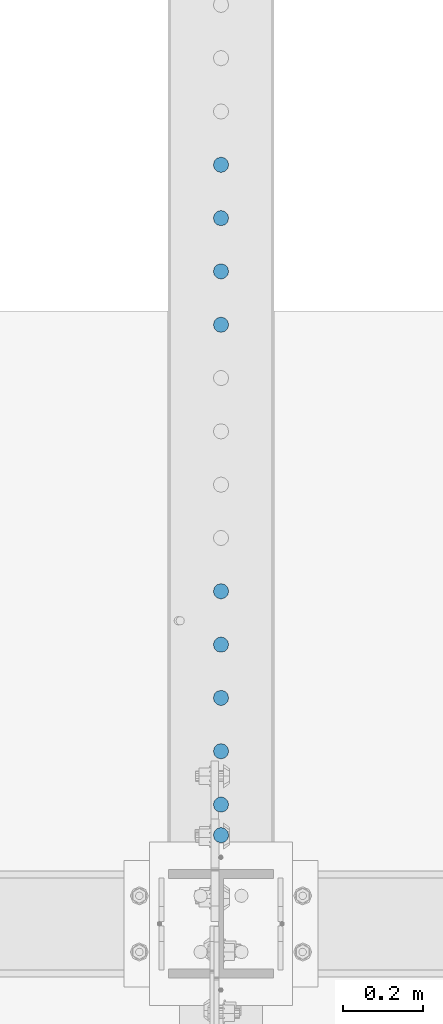
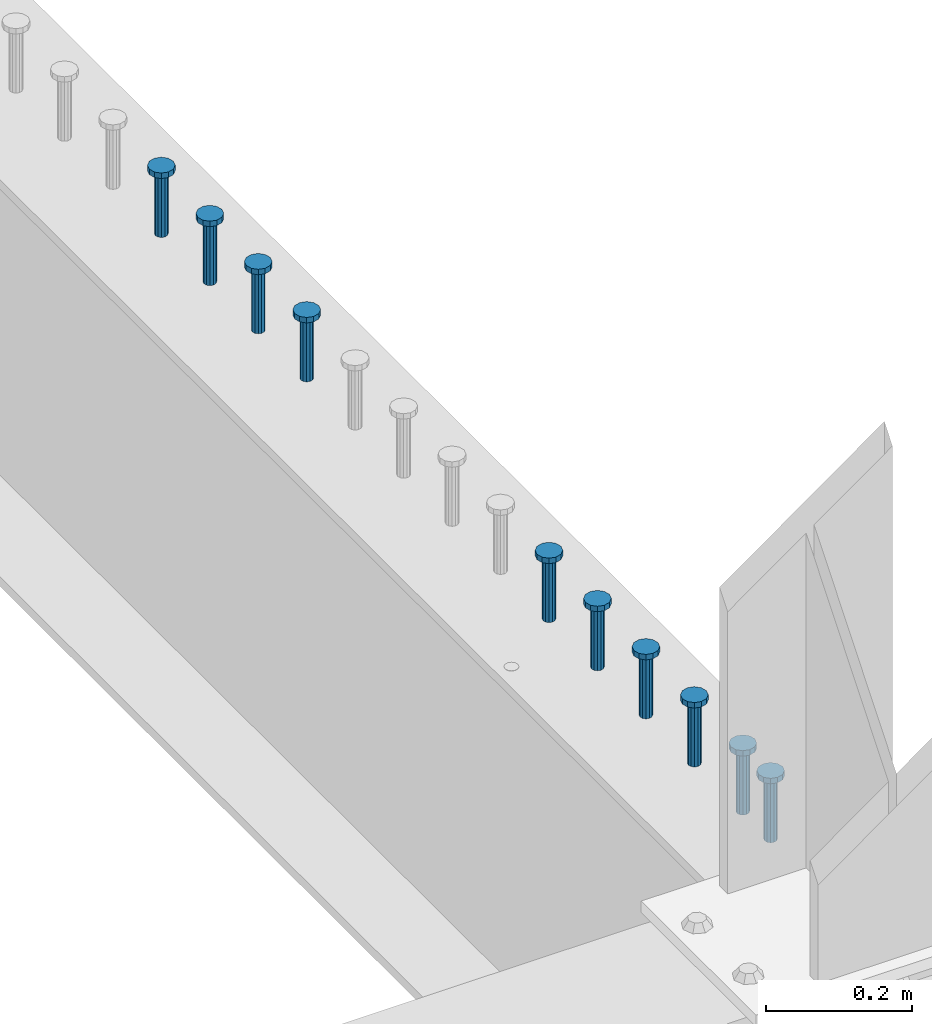
# One storey, part 940 of 1763: 10 columns, 10 elements without a shape of their own.
"""IFC2X3 building model written with IfcOpenShell, lengths in millimetres."""

from ifc_helpers import new_model, si_unit, frame, origin_with_axes, place, context, subcontext, project, spatial, faceted_brep, material, type_object, element, aggregate, save


model = new_model("IFC2X3")

# Units and contexts
model_context = context("Model", 3, precision=1e-05, world=origin_with_axes())
body_context = subcontext(model_context, "Body", "Model", "MODEL_VIEW")
ifc_project = project(units=[si_unit("LENGTHUNIT", "METRE", prefix="MILLI"), si_unit("AREAUNIT", "SQUARE_METRE"), si_unit("VOLUMEUNIT", "CUBIC_METRE"), si_unit("MASSUNIT", "GRAM", prefix="KILO"), si_unit("TIMEUNIT", "SECOND"), si_unit("PLANEANGLEUNIT", "RADIAN"), si_unit("SOLIDANGLEUNIT", "STERADIAN"), si_unit("THERMODYNAMICTEMPERATUREUNIT", "DEGREE_CELSIUS"), si_unit("LUMINOUSINTENSITYUNIT", "LUMEN")], contexts=[model_context])

# Site, building, storey
site_placement = place(None, origin_with_axes())
site = spatial("IfcSite", under=ifc_project, at=site_placement, CompositionType="ELEMENT")
building_placement = place(site_placement, origin_with_axes())
building = spatial("IfcBuilding", under=site, at=building_placement, Name="Undefined", CompositionType="ELEMENT")
storey_placement = place(building_placement, origin_with_axes())
storey = spatial("IfcBuildingStorey", under=building, at=storey_placement, Name="Undefined", CompositionType="ELEMENT", Elevation=0.0)

# Assembly, column
assembly_1_placement = place(storey_placement, origin_with_axes())
assembly_1 = element("IfcElementAssembly", 1, at=assembly_1_placement, inside=storey, Name="STUD", AssemblyPlace="NOTDEFINED", PredefinedType="RIGID_FRAME")
ifc_material = material(Name="STEEL/A108")
column_type = type_object("IfcColumnType", Name="STUD_3/4-DIA", PredefinedType="NOTDEFINED")
column_1_placement = place(assembly_1_placement, frame((-24027.8372736984, 30243.4625, 5194.3), z_axis=(-1.0, 0.0, 0.0), x_axis=(0.0, 0.0, 1.0)))
column_1 = element("IfcColumn", 2, at=column_1_placement, type_object=column_type, material=ifc_material, Name="STUD", ObjectType="STUD_3/4-DIA", context=body_context, shape_type="Brep", body=[
    faceted_brep([(0.0, -9.52000045776367, 0.0), (0.0, -8.25, -4.76000022888184), (104.013, -8.25, -4.76000022888184), (104.013, -9.52000045776367, 0.0), (0.0, -4.76000022888184, -8.25), (104.013, -4.76000022888184, -8.25), (0.0, 0.0, -9.52000045776367), (104.013, 0.0, -9.52000045776367), (0.0, 4.76000022888184, -8.25), (104.013, 4.76000022888184, -8.25), (0.0, 8.25, -4.76000022888184), (104.013, 8.25, -4.76000022888184), (0.0, 9.52000045776367, 0.0), (104.013, 9.52000045776367, 0.0), (0.0, 8.25, 4.76000022888184), (104.013, 8.25, 4.76000022888184), (0.0, 4.76000022888184, 8.25), (104.013, 4.76000022888184, 8.25), (0.0, 0.0, 9.52000045776367), (104.013, 0.0, 9.52000045776367), (0.0, -4.76000022888184, 8.25), (104.013, -4.76000022888184, 8.25), (0.0, -8.25, 4.76000022888184), (104.013, -8.25, 4.76000022888184), (105.156, -16.5, -9.52000045776367), (105.156, -19.0499992370605, 0.0), (105.156, -9.52000045776367, -16.5), (105.156, 0.0, -19.0499992370605), (105.156, 9.52000045776367, -16.5), (105.156, 16.5, -9.52000045776367), (105.156, 19.0499992370605, 0.0), (105.156, 16.5, 9.52000045776367), (105.156, 9.52000045776367, 16.5), (105.156, 0.0, 19.0499992370605), (105.156, -9.52000045776367, 16.5), (105.156, -16.5, 9.52000045776367), (114.3, -16.5, -9.52000045776367), (114.299998441489, -19.0500000000029, 0.0), (114.3, -9.52000045776367, -16.5), (114.3, 0.0, -19.0499992370605), (114.3, 9.52000045776367, -16.5), (114.3, 16.5, -9.52000045776367), (114.299998441489, 19.0500000000029, 0.0), (114.3, 16.5, 9.52000045776367), (114.3, 9.52000045776367, 16.5), (114.3, 0.0, 19.0499992370605), (114.3, -9.52000045776367, 16.5), (114.3, -16.5, 9.52000045776367)], [[[0, 1, 2, 3]], [[1, 4, 5, 2]], [[4, 6, 7, 5]], [[6, 8, 9, 7]], [[8, 10, 11, 9]], [[10, 12, 13, 11]], [[12, 14, 15, 13]], [[14, 16, 17, 15]], [[16, 18, 19, 17]], [[18, 20, 21, 19]], [[20, 22, 23, 21]], [[22, 0, 3, 23]], [[22, 20, 18, 16, 14, 12, 10, 8, 6, 4, 1, 0]], [[3, 2, 24, 25]], [[2, 5, 26, 24]], [[5, 7, 27, 26]], [[7, 9, 28, 27]], [[9, 11, 29, 28]], [[11, 13, 30, 29]], [[13, 15, 31, 30]], [[15, 17, 32, 31]], [[17, 19, 33, 32]], [[19, 21, 34, 33]], [[21, 23, 35, 34]], [[23, 3, 25, 35]], [[25, 24, 36, 37]], [[24, 26, 38, 36]], [[26, 27, 39, 38]], [[27, 28, 40, 39]], [[28, 29, 41, 40]], [[29, 30, 42, 41]], [[30, 31, 43, 42]], [[31, 32, 44, 43]], [[32, 33, 45, 44]], [[33, 34, 46, 45]], [[34, 35, 47, 46]], [[35, 25, 37, 47]], [[38, 39, 40, 41, 42, 43, 44, 45, 46, 47, 37, 36]]]),
])
aggregate(assembly_1, [column_1])

assembly_2_placement = place(storey_placement, origin_with_axes())
assembly_2 = element("IfcElementAssembly", 3, at=assembly_2_placement, inside=storey, Name="STUD", AssemblyPlace="NOTDEFINED", PredefinedType="RIGID_FRAME")
column_2_placement = place(assembly_2_placement, frame((-24027.8372736984, 31910.9585, 5194.3), z_axis=(-1.0, 0.0, 0.0), x_axis=(0.0, 0.0, 1.0)))
column_2 = element("IfcColumn", 4, at=column_2_placement, type_object=column_type, material=ifc_material, Name="STUD", ObjectType="STUD_3/4-DIA", context=body_context, shape_type="Brep", body=[
    faceted_brep([(0.0, -9.52000045776367, 0.0), (0.0, -8.25, -4.76000022888184), (104.013, -8.25, -4.76000022888184), (104.013, -9.52000045776367, 0.0), (0.0, -4.76000022888184, -8.25), (104.013, -4.76000022888184, -8.25), (0.0, 0.0, -9.52000045776367), (104.013, 0.0, -9.52000045776367), (0.0, 4.76000022888184, -8.25), (104.013, 4.76000022888184, -8.25), (0.0, 8.25, -4.76000022888184), (104.013, 8.25, -4.76000022888184), (0.0, 9.52000045776367, 0.0), (104.013, 9.52000045776367, 0.0), (0.0, 8.25, 4.76000022888184), (104.013, 8.25, 4.76000022888184), (0.0, 4.76000022888184, 8.25), (104.013, 4.76000022888184, 8.25), (0.0, 0.0, 9.52000045776367), (104.013, 0.0, 9.52000045776367), (0.0, -4.76000022888184, 8.25), (104.013, -4.76000022888184, 8.25), (0.0, -8.25, 4.76000022888184), (104.013, -8.25, 4.76000022888184), (105.156, -16.5, -9.52000045776367), (105.156, -19.0499992370605, 0.0), (105.156, -9.52000045776367, -16.5), (105.156, 0.0, -19.0499992370605), (105.156, 9.52000045776367, -16.5), (105.156, 16.5, -9.52000045776367), (105.156, 19.0499992370605, 0.0), (105.156, 16.5, 9.52000045776367), (105.156, 9.52000045776367, 16.5), (105.156, 0.0, 19.0499992370605), (105.156, -9.52000045776367, 16.5), (105.156, -16.5, 9.52000045776367), (114.3, -16.5, -9.52000045776367), (114.299998441489, -19.0500000000029, 0.0), (114.3, -9.52000045776367, -16.5), (114.3, 0.0, -19.0499992370605), (114.3, 9.52000045776367, -16.5), (114.3, 16.5, -9.52000045776367), (114.299998441489, 19.0500000000029, 0.0), (114.3, 16.5, 9.52000045776367), (114.3, 9.52000045776367, 16.5), (114.3, 0.0, 19.0499992370605), (114.3, -9.52000045776367, 16.5), (114.3, -16.5, 9.52000045776367)], [[[0, 1, 2, 3]], [[1, 4, 5, 2]], [[4, 6, 7, 5]], [[6, 8, 9, 7]], [[8, 10, 11, 9]], [[10, 12, 13, 11]], [[12, 14, 15, 13]], [[14, 16, 17, 15]], [[16, 18, 19, 17]], [[18, 20, 21, 19]], [[20, 22, 23, 21]], [[22, 0, 3, 23]], [[22, 20, 18, 16, 14, 12, 10, 8, 6, 4, 1, 0]], [[3, 2, 24, 25]], [[2, 5, 26, 24]], [[5, 7, 27, 26]], [[7, 9, 28, 27]], [[9, 11, 29, 28]], [[11, 13, 30, 29]], [[13, 15, 31, 30]], [[15, 17, 32, 31]], [[17, 19, 33, 32]], [[19, 21, 34, 33]], [[21, 23, 35, 34]], [[23, 3, 25, 35]], [[25, 24, 36, 37]], [[24, 26, 38, 36]], [[26, 27, 39, 38]], [[27, 28, 40, 39]], [[28, 29, 41, 40]], [[29, 30, 42, 41]], [[30, 31, 43, 42]], [[31, 32, 44, 43]], [[32, 33, 45, 44]], [[33, 34, 46, 45]], [[34, 35, 47, 46]], [[35, 25, 37, 47]], [[38, 39, 40, 41, 42, 43, 44, 45, 46, 47, 37, 36]]]),
])
aggregate(assembly_2, [column_2])

assembly_3_placement = place(storey_placement, origin_with_axes())
assembly_3 = element("IfcElementAssembly", 5, at=assembly_3_placement, inside=storey, Name="STUD", AssemblyPlace="NOTDEFINED", PredefinedType="RIGID_FRAME")
column_3_placement = place(assembly_3_placement, frame((-24027.8372736984, 31778.3505, 5194.3), z_axis=(-1.0, 0.0, 0.0), x_axis=(0.0, 0.0, 1.0)))
column_3 = element("IfcColumn", 6, at=column_3_placement, type_object=column_type, material=ifc_material, Name="STUD", ObjectType="STUD_3/4-DIA", context=body_context, shape_type="Brep", body=[
    faceted_brep([(0.0, -9.52000045776367, 0.0), (0.0, -8.25, -4.76000022888184), (104.013, -8.25, -4.76000022888184), (104.013, -9.52000045776367, 0.0), (0.0, -4.76000022888184, -8.25), (104.013, -4.76000022888184, -8.25), (0.0, 0.0, -9.52000045776367), (104.013, 0.0, -9.52000045776367), (0.0, 4.76000022888184, -8.25), (104.013, 4.76000022888184, -8.25), (0.0, 8.25, -4.76000022888184), (104.013, 8.25, -4.76000022888184), (0.0, 9.52000045776367, 0.0), (104.013, 9.52000045776367, 0.0), (0.0, 8.25, 4.76000022888184), (104.013, 8.25, 4.76000022888184), (0.0, 4.76000022888184, 8.25), (104.013, 4.76000022888184, 8.25), (0.0, 0.0, 9.52000045776367), (104.013, 0.0, 9.52000045776367), (0.0, -4.76000022888184, 8.25), (104.013, -4.76000022888184, 8.25), (0.0, -8.25, 4.76000022888184), (104.013, -8.25, 4.76000022888184), (105.156, -16.5, -9.52000045776367), (105.156, -19.0499992370605, 0.0), (105.156, -9.52000045776367, -16.5), (105.156, 0.0, -19.0499992370605), (105.156, 9.52000045776367, -16.5), (105.156, 16.5, -9.52000045776367), (105.156, 19.0499992370605, 0.0), (105.156, 16.5, 9.52000045776367), (105.156, 9.52000045776367, 16.5), (105.156, 0.0, 19.0499992370605), (105.156, -9.52000045776367, 16.5), (105.156, -16.5, 9.52000045776367), (114.3, -16.5, -9.52000045776367), (114.299998441489, -19.0500000000029, 0.0), (114.3, -9.52000045776367, -16.5), (114.3, 0.0, -19.0499992370605), (114.3, 9.52000045776367, -16.5), (114.3, 16.5, -9.52000045776367), (114.299998441489, 19.0500000000029, 0.0), (114.3, 16.5, 9.52000045776367), (114.3, 9.52000045776367, 16.5), (114.3, 0.0, 19.0499992370605), (114.3, -9.52000045776367, 16.5), (114.3, -16.5, 9.52000045776367)], [[[0, 1, 2, 3]], [[1, 4, 5, 2]], [[4, 6, 7, 5]], [[6, 8, 9, 7]], [[8, 10, 11, 9]], [[10, 12, 13, 11]], [[12, 14, 15, 13]], [[14, 16, 17, 15]], [[16, 18, 19, 17]], [[18, 20, 21, 19]], [[20, 22, 23, 21]], [[22, 0, 3, 23]], [[22, 20, 18, 16, 14, 12, 10, 8, 6, 4, 1, 0]], [[3, 2, 24, 25]], [[2, 5, 26, 24]], [[5, 7, 27, 26]], [[7, 9, 28, 27]], [[9, 11, 29, 28]], [[11, 13, 30, 29]], [[13, 15, 31, 30]], [[15, 17, 32, 31]], [[17, 19, 33, 32]], [[19, 21, 34, 33]], [[21, 23, 35, 34]], [[23, 3, 25, 35]], [[25, 24, 36, 37]], [[24, 26, 38, 36]], [[26, 27, 39, 38]], [[27, 28, 40, 39]], [[28, 29, 41, 40]], [[29, 30, 42, 41]], [[30, 31, 43, 42]], [[31, 32, 44, 43]], [[32, 33, 45, 44]], [[33, 34, 46, 45]], [[34, 35, 47, 46]], [[35, 25, 37, 47]], [[38, 39, 40, 41, 42, 43, 44, 45, 46, 47, 37, 36]]]),
])
aggregate(assembly_3, [column_3])

assembly_4_placement = place(storey_placement, origin_with_axes())
assembly_4 = element("IfcElementAssembly", 7, at=assembly_4_placement, inside=storey, Name="STUD", AssemblyPlace="NOTDEFINED", PredefinedType="RIGID_FRAME")
column_4_placement = place(assembly_4_placement, frame((-24027.8372736984, 31645.7425, 5194.3), z_axis=(-1.0, 0.0, 0.0), x_axis=(0.0, 0.0, 1.0)))
column_4 = element("IfcColumn", 8, at=column_4_placement, type_object=column_type, material=ifc_material, Name="STUD", ObjectType="STUD_3/4-DIA", context=body_context, shape_type="Brep", body=[
    faceted_brep([(0.0, -9.52000045776367, 0.0), (0.0, -8.25, -4.76000022888184), (104.013, -8.25, -4.76000022888184), (104.013, -9.52000045776367, 0.0), (0.0, -4.76000022888184, -8.25), (104.013, -4.76000022888184, -8.25), (0.0, 0.0, -9.52000045776367), (104.013, 0.0, -9.52000045776367), (0.0, 4.76000022888184, -8.25), (104.013, 4.76000022888184, -8.25), (0.0, 8.25, -4.76000022888184), (104.013, 8.25, -4.76000022888184), (0.0, 9.52000045776367, 0.0), (104.013, 9.52000045776367, 0.0), (0.0, 8.25, 4.76000022888184), (104.013, 8.25, 4.76000022888184), (0.0, 4.76000022888184, 8.25), (104.013, 4.76000022888184, 8.25), (0.0, 0.0, 9.52000045776367), (104.013, 0.0, 9.52000045776367), (0.0, -4.76000022888184, 8.25), (104.013, -4.76000022888184, 8.25), (0.0, -8.25, 4.76000022888184), (104.013, -8.25, 4.76000022888184), (105.156, -16.5, -9.52000045776367), (105.156, -19.0499992370605, 0.0), (105.156, -9.52000045776367, -16.5), (105.156, 0.0, -19.0499992370605), (105.156, 9.52000045776367, -16.5), (105.156, 16.5, -9.52000045776367), (105.156, 19.0499992370605, 0.0), (105.156, 16.5, 9.52000045776367), (105.156, 9.52000045776367, 16.5), (105.156, 0.0, 19.0499992370605), (105.156, -9.52000045776367, 16.5), (105.156, -16.5, 9.52000045776367), (114.3, -16.5, -9.52000045776367), (114.299998441489, -19.0500000000029, 0.0), (114.3, -9.52000045776367, -16.5), (114.3, 0.0, -19.0499992370605), (114.3, 9.52000045776367, -16.5), (114.3, 16.5, -9.52000045776367), (114.299998441489, 19.0500000000029, 0.0), (114.3, 16.5, 9.52000045776367), (114.3, 9.52000045776367, 16.5), (114.3, 0.0, 19.0499992370605), (114.3, -9.52000045776367, 16.5), (114.3, -16.5, 9.52000045776367)], [[[0, 1, 2, 3]], [[1, 4, 5, 2]], [[4, 6, 7, 5]], [[6, 8, 9, 7]], [[8, 10, 11, 9]], [[10, 12, 13, 11]], [[12, 14, 15, 13]], [[14, 16, 17, 15]], [[16, 18, 19, 17]], [[18, 20, 21, 19]], [[20, 22, 23, 21]], [[22, 0, 3, 23]], [[22, 20, 18, 16, 14, 12, 10, 8, 6, 4, 1, 0]], [[3, 2, 24, 25]], [[2, 5, 26, 24]], [[5, 7, 27, 26]], [[7, 9, 28, 27]], [[9, 11, 29, 28]], [[11, 13, 30, 29]], [[13, 15, 31, 30]], [[15, 17, 32, 31]], [[17, 19, 33, 32]], [[19, 21, 34, 33]], [[21, 23, 35, 34]], [[23, 3, 25, 35]], [[25, 24, 36, 37]], [[24, 26, 38, 36]], [[26, 27, 39, 38]], [[27, 28, 40, 39]], [[28, 29, 41, 40]], [[29, 30, 42, 41]], [[30, 31, 43, 42]], [[31, 32, 44, 43]], [[32, 33, 45, 44]], [[33, 34, 46, 45]], [[34, 35, 47, 46]], [[35, 25, 37, 47]], [[38, 39, 40, 41, 42, 43, 44, 45, 46, 47, 37, 36]]]),
])
aggregate(assembly_4, [column_4])

assembly_5_placement = place(storey_placement, origin_with_axes())
assembly_5 = element("IfcElementAssembly", 9, at=assembly_5_placement, inside=storey, Name="STUD", AssemblyPlace="NOTDEFINED", PredefinedType="RIGID_FRAME")
column_5_placement = place(assembly_5_placement, frame((-24027.8372736984, 31513.1345, 5194.3), z_axis=(-1.0, 0.0, 0.0), x_axis=(0.0, 0.0, 1.0)))
column_5 = element("IfcColumn", 10, at=column_5_placement, type_object=column_type, material=ifc_material, Name="STUD", ObjectType="STUD_3/4-DIA", context=body_context, shape_type="Brep", body=[
    faceted_brep([(0.0, -9.52000045776367, 0.0), (0.0, -8.25, -4.76000022888184), (104.013, -8.25, -4.76000022888184), (104.013, -9.52000045776367, 0.0), (0.0, -4.76000022888184, -8.25), (104.013, -4.76000022888184, -8.25), (0.0, 0.0, -9.52000045776367), (104.013, 0.0, -9.52000045776367), (0.0, 4.76000022888184, -8.25), (104.013, 4.76000022888184, -8.25), (0.0, 8.25, -4.76000022888184), (104.013, 8.25, -4.76000022888184), (0.0, 9.52000045776367, 0.0), (104.013, 9.52000045776367, 0.0), (0.0, 8.25, 4.76000022888184), (104.013, 8.25, 4.76000022888184), (0.0, 4.76000022888184, 8.25), (104.013, 4.76000022888184, 8.25), (0.0, 0.0, 9.52000045776367), (104.013, 0.0, 9.52000045776367), (0.0, -4.76000022888184, 8.25), (104.013, -4.76000022888184, 8.25), (0.0, -8.25, 4.76000022888184), (104.013, -8.25, 4.76000022888184), (105.156, -16.5, -9.52000045776367), (105.156, -19.0499992370605, 0.0), (105.156, -9.52000045776367, -16.5), (105.156, 0.0, -19.0499992370605), (105.156, 9.52000045776367, -16.5), (105.156, 16.5, -9.52000045776367), (105.156, 19.0499992370605, 0.0), (105.156, 16.5, 9.52000045776367), (105.156, 9.52000045776367, 16.5), (105.156, 0.0, 19.0499992370605), (105.156, -9.52000045776367, 16.5), (105.156, -16.5, 9.52000045776367), (114.3, -16.5, -9.52000045776367), (114.299998441489, -19.0500000000029, 0.0), (114.3, -9.52000045776367, -16.5), (114.3, 0.0, -19.0499992370605), (114.3, 9.52000045776367, -16.5), (114.3, 16.5, -9.52000045776367), (114.299998441489, 19.0500000000029, 0.0), (114.3, 16.5, 9.52000045776367), (114.3, 9.52000045776367, 16.5), (114.3, 0.0, 19.0499992370605), (114.3, -9.52000045776367, 16.5), (114.3, -16.5, 9.52000045776367)], [[[0, 1, 2, 3]], [[1, 4, 5, 2]], [[4, 6, 7, 5]], [[6, 8, 9, 7]], [[8, 10, 11, 9]], [[10, 12, 13, 11]], [[12, 14, 15, 13]], [[14, 16, 17, 15]], [[16, 18, 19, 17]], [[18, 20, 21, 19]], [[20, 22, 23, 21]], [[22, 0, 3, 23]], [[22, 20, 18, 16, 14, 12, 10, 8, 6, 4, 1, 0]], [[3, 2, 24, 25]], [[2, 5, 26, 24]], [[5, 7, 27, 26]], [[7, 9, 28, 27]], [[9, 11, 29, 28]], [[11, 13, 30, 29]], [[13, 15, 31, 30]], [[15, 17, 32, 31]], [[17, 19, 33, 32]], [[19, 21, 34, 33]], [[21, 23, 35, 34]], [[23, 3, 25, 35]], [[25, 24, 36, 37]], [[24, 26, 38, 36]], [[26, 27, 39, 38]], [[27, 28, 40, 39]], [[28, 29, 41, 40]], [[29, 30, 42, 41]], [[30, 31, 43, 42]], [[31, 32, 44, 43]], [[32, 33, 45, 44]], [[33, 34, 46, 45]], [[34, 35, 47, 46]], [[35, 25, 37, 47]], [[38, 39, 40, 41, 42, 43, 44, 45, 46, 47, 37, 36]]]),
])
aggregate(assembly_5, [column_5])

assembly_6_placement = place(storey_placement, origin_with_axes())
assembly_6 = element("IfcElementAssembly", 11, at=assembly_6_placement, inside=storey, Name="STUD", AssemblyPlace="NOTDEFINED", PredefinedType="RIGID_FRAME")
column_6_placement = place(assembly_6_placement, frame((-24027.8372736984, 30850.0945, 5194.3), z_axis=(-1.0, 0.0, 0.0), x_axis=(0.0, 0.0, 1.0)))
column_6 = element("IfcColumn", 12, at=column_6_placement, type_object=column_type, material=ifc_material, Name="STUD", ObjectType="STUD_3/4-DIA", context=body_context, shape_type="Brep", body=[
    faceted_brep([(0.0, -9.52000045776367, 0.0), (0.0, -8.25, -4.76000022888184), (104.013, -8.25, -4.76000022888184), (104.013, -9.52000045776367, 0.0), (0.0, -4.76000022888184, -8.25), (104.013, -4.76000022888184, -8.25), (0.0, 0.0, -9.52000045776367), (104.013, 0.0, -9.52000045776367), (0.0, 4.76000022888184, -8.25), (104.013, 4.76000022888184, -8.25), (0.0, 8.25, -4.76000022888184), (104.013, 8.25, -4.76000022888184), (0.0, 9.52000045776367, 0.0), (104.013, 9.52000045776367, 0.0), (0.0, 8.25, 4.76000022888184), (104.013, 8.25, 4.76000022888184), (0.0, 4.76000022888184, 8.25), (104.013, 4.76000022888184, 8.25), (0.0, 0.0, 9.52000045776367), (104.013, 0.0, 9.52000045776367), (0.0, -4.76000022888184, 8.25), (104.013, -4.76000022888184, 8.25), (0.0, -8.25, 4.76000022888184), (104.013, -8.25, 4.76000022888184), (105.156, -16.5, -9.52000045776367), (105.156, -19.0499992370605, 0.0), (105.156, -9.52000045776367, -16.5), (105.156, 0.0, -19.0499992370605), (105.156, 9.52000045776367, -16.5), (105.156, 16.5, -9.52000045776367), (105.156, 19.0499992370605, 0.0), (105.156, 16.5, 9.52000045776367), (105.156, 9.52000045776367, 16.5), (105.156, 0.0, 19.0499992370605), (105.156, -9.52000045776367, 16.5), (105.156, -16.5, 9.52000045776367), (114.3, -16.5, -9.52000045776367), (114.299998441489, -19.0500000000029, 0.0), (114.3, -9.52000045776367, -16.5), (114.3, 0.0, -19.0499992370605), (114.3, 9.52000045776367, -16.5), (114.3, 16.5, -9.52000045776367), (114.299998441489, 19.0500000000029, 0.0), (114.3, 16.5, 9.52000045776367), (114.3, 9.52000045776367, 16.5), (114.3, 0.0, 19.0499992370605), (114.3, -9.52000045776367, 16.5), (114.3, -16.5, 9.52000045776367)], [[[0, 1, 2, 3]], [[1, 4, 5, 2]], [[4, 6, 7, 5]], [[6, 8, 9, 7]], [[8, 10, 11, 9]], [[10, 12, 13, 11]], [[12, 14, 15, 13]], [[14, 16, 17, 15]], [[16, 18, 19, 17]], [[18, 20, 21, 19]], [[20, 22, 23, 21]], [[22, 0, 3, 23]], [[22, 20, 18, 16, 14, 12, 10, 8, 6, 4, 1, 0]], [[3, 2, 24, 25]], [[2, 5, 26, 24]], [[5, 7, 27, 26]], [[7, 9, 28, 27]], [[9, 11, 29, 28]], [[11, 13, 30, 29]], [[13, 15, 31, 30]], [[15, 17, 32, 31]], [[17, 19, 33, 32]], [[19, 21, 34, 33]], [[21, 23, 35, 34]], [[23, 3, 25, 35]], [[25, 24, 36, 37]], [[24, 26, 38, 36]], [[26, 27, 39, 38]], [[27, 28, 40, 39]], [[28, 29, 41, 40]], [[29, 30, 42, 41]], [[30, 31, 43, 42]], [[31, 32, 44, 43]], [[32, 33, 45, 44]], [[33, 34, 46, 45]], [[34, 35, 47, 46]], [[35, 25, 37, 47]], [[38, 39, 40, 41, 42, 43, 44, 45, 46, 47, 37, 36]]]),
])
aggregate(assembly_6, [column_6])

assembly_7_placement = place(storey_placement, origin_with_axes())
assembly_7 = element("IfcElementAssembly", 13, at=assembly_7_placement, inside=storey, Name="STUD", AssemblyPlace="NOTDEFINED", PredefinedType="RIGID_FRAME")
column_7_placement = place(assembly_7_placement, frame((-24027.8372736984, 30717.4865, 5194.3), z_axis=(-1.0, 0.0, 0.0), x_axis=(0.0, 0.0, 1.0)))
column_7 = element("IfcColumn", 14, at=column_7_placement, type_object=column_type, material=ifc_material, Name="STUD", ObjectType="STUD_3/4-DIA", context=body_context, shape_type="Brep", body=[
    faceted_brep([(0.0, -9.52000045776367, 0.0), (0.0, -8.25, -4.76000022888184), (104.013, -8.25, -4.76000022888184), (104.013, -9.52000045776367, 0.0), (0.0, -4.76000022888184, -8.25), (104.013, -4.76000022888184, -8.25), (0.0, 0.0, -9.52000045776367), (104.013, 0.0, -9.52000045776367), (0.0, 4.76000022888184, -8.25), (104.013, 4.76000022888184, -8.25), (0.0, 8.25, -4.76000022888184), (104.013, 8.25, -4.76000022888184), (0.0, 9.52000045776367, 0.0), (104.013, 9.52000045776367, 0.0), (0.0, 8.25, 4.76000022888184), (104.013, 8.25, 4.76000022888184), (0.0, 4.76000022888184, 8.25), (104.013, 4.76000022888184, 8.25), (0.0, 0.0, 9.52000045776367), (104.013, 0.0, 9.52000045776367), (0.0, -4.76000022888184, 8.25), (104.013, -4.76000022888184, 8.25), (0.0, -8.25, 4.76000022888184), (104.013, -8.25, 4.76000022888184), (105.156, -16.5, -9.52000045776367), (105.156, -19.0499992370605, 0.0), (105.156, -9.52000045776367, -16.5), (105.156, 0.0, -19.0499992370605), (105.156, 9.52000045776367, -16.5), (105.156, 16.5, -9.52000045776367), (105.156, 19.0499992370605, 0.0), (105.156, 16.5, 9.52000045776367), (105.156, 9.52000045776367, 16.5), (105.156, 0.0, 19.0499992370605), (105.156, -9.52000045776367, 16.5), (105.156, -16.5, 9.52000045776367), (114.3, -16.5, -9.52000045776367), (114.299998441489, -19.0500000000029, 0.0), (114.3, -9.52000045776367, -16.5), (114.3, 0.0, -19.0499992370605), (114.3, 9.52000045776367, -16.5), (114.3, 16.5, -9.52000045776367), (114.299998441489, 19.0500000000029, 0.0), (114.3, 16.5, 9.52000045776367), (114.3, 9.52000045776367, 16.5), (114.3, 0.0, 19.0499992370605), (114.3, -9.52000045776367, 16.5), (114.3, -16.5, 9.52000045776367)], [[[0, 1, 2, 3]], [[1, 4, 5, 2]], [[4, 6, 7, 5]], [[6, 8, 9, 7]], [[8, 10, 11, 9]], [[10, 12, 13, 11]], [[12, 14, 15, 13]], [[14, 16, 17, 15]], [[16, 18, 19, 17]], [[18, 20, 21, 19]], [[20, 22, 23, 21]], [[22, 0, 3, 23]], [[22, 20, 18, 16, 14, 12, 10, 8, 6, 4, 1, 0]], [[3, 2, 24, 25]], [[2, 5, 26, 24]], [[5, 7, 27, 26]], [[7, 9, 28, 27]], [[9, 11, 29, 28]], [[11, 13, 30, 29]], [[13, 15, 31, 30]], [[15, 17, 32, 31]], [[17, 19, 33, 32]], [[19, 21, 34, 33]], [[21, 23, 35, 34]], [[23, 3, 25, 35]], [[25, 24, 36, 37]], [[24, 26, 38, 36]], [[26, 27, 39, 38]], [[27, 28, 40, 39]], [[28, 29, 41, 40]], [[29, 30, 42, 41]], [[30, 31, 43, 42]], [[31, 32, 44, 43]], [[32, 33, 45, 44]], [[33, 34, 46, 45]], [[34, 35, 47, 46]], [[35, 25, 37, 47]], [[38, 39, 40, 41, 42, 43, 44, 45, 46, 47, 37, 36]]]),
])
aggregate(assembly_7, [column_7])

assembly_8_placement = place(storey_placement, origin_with_axes())
assembly_8 = element("IfcElementAssembly", 15, at=assembly_8_placement, inside=storey, Name="STUD", AssemblyPlace="NOTDEFINED", PredefinedType="RIGID_FRAME")
column_8_placement = place(assembly_8_placement, frame((-24027.8372736984, 30584.8785, 5194.3), z_axis=(-1.0, 0.0, 0.0), x_axis=(0.0, 0.0, 1.0)))
column_8 = element("IfcColumn", 16, at=column_8_placement, type_object=column_type, material=ifc_material, Name="STUD", ObjectType="STUD_3/4-DIA", context=body_context, shape_type="Brep", body=[
    faceted_brep([(0.0, -9.52000045776367, 0.0), (0.0, -8.25, -4.76000022888184), (104.013, -8.25, -4.76000022888184), (104.013, -9.52000045776367, 0.0), (0.0, -4.76000022888184, -8.25), (104.013, -4.76000022888184, -8.25), (0.0, 0.0, -9.52000045776367), (104.013, 0.0, -9.52000045776367), (0.0, 4.76000022888184, -8.25), (104.013, 4.76000022888184, -8.25), (0.0, 8.25, -4.76000022888184), (104.013, 8.25, -4.76000022888184), (0.0, 9.52000045776367, 0.0), (104.013, 9.52000045776367, 0.0), (0.0, 8.25, 4.76000022888184), (104.013, 8.25, 4.76000022888184), (0.0, 4.76000022888184, 8.25), (104.013, 4.76000022888184, 8.25), (0.0, 0.0, 9.52000045776367), (104.013, 0.0, 9.52000045776367), (0.0, -4.76000022888184, 8.25), (104.013, -4.76000022888184, 8.25), (0.0, -8.25, 4.76000022888184), (104.013, -8.25, 4.76000022888184), (105.156, -16.5, -9.52000045776367), (105.156, -19.0499992370605, 0.0), (105.156, -9.52000045776367, -16.5), (105.156, 0.0, -19.0499992370605), (105.156, 9.52000045776367, -16.5), (105.156, 16.5, -9.52000045776367), (105.156, 19.0499992370605, 0.0), (105.156, 16.5, 9.52000045776367), (105.156, 9.52000045776367, 16.5), (105.156, 0.0, 19.0499992370605), (105.156, -9.52000045776367, 16.5), (105.156, -16.5, 9.52000045776367), (114.3, -16.5, -9.52000045776367), (114.299998441489, -19.0500000000029, 0.0), (114.3, -9.52000045776367, -16.5), (114.3, 0.0, -19.0499992370605), (114.3, 9.52000045776367, -16.5), (114.3, 16.5, -9.52000045776367), (114.299998441489, 19.0500000000029, 0.0), (114.3, 16.5, 9.52000045776367), (114.3, 9.52000045776367, 16.5), (114.3, 0.0, 19.0499992370605), (114.3, -9.52000045776367, 16.5), (114.3, -16.5, 9.52000045776367)], [[[0, 1, 2, 3]], [[1, 4, 5, 2]], [[4, 6, 7, 5]], [[6, 8, 9, 7]], [[8, 10, 11, 9]], [[10, 12, 13, 11]], [[12, 14, 15, 13]], [[14, 16, 17, 15]], [[16, 18, 19, 17]], [[18, 20, 21, 19]], [[20, 22, 23, 21]], [[22, 0, 3, 23]], [[22, 20, 18, 16, 14, 12, 10, 8, 6, 4, 1, 0]], [[3, 2, 24, 25]], [[2, 5, 26, 24]], [[5, 7, 27, 26]], [[7, 9, 28, 27]], [[9, 11, 29, 28]], [[11, 13, 30, 29]], [[13, 15, 31, 30]], [[15, 17, 32, 31]], [[17, 19, 33, 32]], [[19, 21, 34, 33]], [[21, 23, 35, 34]], [[23, 3, 25, 35]], [[25, 24, 36, 37]], [[24, 26, 38, 36]], [[26, 27, 39, 38]], [[27, 28, 40, 39]], [[28, 29, 41, 40]], [[29, 30, 42, 41]], [[30, 31, 43, 42]], [[31, 32, 44, 43]], [[32, 33, 45, 44]], [[33, 34, 46, 45]], [[34, 35, 47, 46]], [[35, 25, 37, 47]], [[38, 39, 40, 41, 42, 43, 44, 45, 46, 47, 37, 36]]]),
])
aggregate(assembly_8, [column_8])

assembly_9_placement = place(storey_placement, origin_with_axes())
assembly_9 = element("IfcElementAssembly", 17, at=assembly_9_placement, inside=storey, Name="STUD", AssemblyPlace="NOTDEFINED", PredefinedType="RIGID_FRAME")
column_9_placement = place(assembly_9_placement, frame((-24027.8372736984, 30452.2705, 5194.3), z_axis=(-1.0, 0.0, 0.0), x_axis=(0.0, 0.0, 1.0)))
column_9 = element("IfcColumn", 18, at=column_9_placement, type_object=column_type, material=ifc_material, Name="STUD", ObjectType="STUD_3/4-DIA", context=body_context, shape_type="Brep", body=[
    faceted_brep([(0.0, -9.52000045776367, 0.0), (0.0, -8.25, -4.76000022888184), (104.013, -8.25, -4.76000022888184), (104.013, -9.52000045776367, 0.0), (0.0, -4.76000022888184, -8.25), (104.013, -4.76000022888184, -8.25), (0.0, 0.0, -9.52000045776367), (104.013, 0.0, -9.52000045776367), (0.0, 4.76000022888184, -8.25), (104.013, 4.76000022888184, -8.25), (0.0, 8.25, -4.76000022888184), (104.013, 8.25, -4.76000022888184), (0.0, 9.52000045776367, 0.0), (104.013, 9.52000045776367, 0.0), (0.0, 8.25, 4.76000022888184), (104.013, 8.25, 4.76000022888184), (0.0, 4.76000022888184, 8.25), (104.013, 4.76000022888184, 8.25), (0.0, 0.0, 9.52000045776367), (104.013, 0.0, 9.52000045776367), (0.0, -4.76000022888184, 8.25), (104.013, -4.76000022888184, 8.25), (0.0, -8.25, 4.76000022888184), (104.013, -8.25, 4.76000022888184), (105.156, -16.5, -9.52000045776367), (105.156, -19.0499992370605, 0.0), (105.156, -9.52000045776367, -16.5), (105.156, 0.0, -19.0499992370605), (105.156, 9.52000045776367, -16.5), (105.156, 16.5, -9.52000045776367), (105.156, 19.0499992370605, 0.0), (105.156, 16.5, 9.52000045776367), (105.156, 9.52000045776367, 16.5), (105.156, 0.0, 19.0499992370605), (105.156, -9.52000045776367, 16.5), (105.156, -16.5, 9.52000045776367), (114.3, -16.5, -9.52000045776367), (114.299998441489, -19.0500000000029, 0.0), (114.3, -9.52000045776367, -16.5), (114.3, 0.0, -19.0499992370605), (114.3, 9.52000045776367, -16.5), (114.3, 16.5, -9.52000045776367), (114.299998441489, 19.0500000000029, 0.0), (114.3, 16.5, 9.52000045776367), (114.3, 9.52000045776367, 16.5), (114.3, 0.0, 19.0499992370605), (114.3, -9.52000045776367, 16.5), (114.3, -16.5, 9.52000045776367)], [[[0, 1, 2, 3]], [[1, 4, 5, 2]], [[4, 6, 7, 5]], [[6, 8, 9, 7]], [[8, 10, 11, 9]], [[10, 12, 13, 11]], [[12, 14, 15, 13]], [[14, 16, 17, 15]], [[16, 18, 19, 17]], [[18, 20, 21, 19]], [[20, 22, 23, 21]], [[22, 0, 3, 23]], [[22, 20, 18, 16, 14, 12, 10, 8, 6, 4, 1, 0]], [[3, 2, 24, 25]], [[2, 5, 26, 24]], [[5, 7, 27, 26]], [[7, 9, 28, 27]], [[9, 11, 29, 28]], [[11, 13, 30, 29]], [[13, 15, 31, 30]], [[15, 17, 32, 31]], [[17, 19, 33, 32]], [[19, 21, 34, 33]], [[21, 23, 35, 34]], [[23, 3, 25, 35]], [[25, 24, 36, 37]], [[24, 26, 38, 36]], [[26, 27, 39, 38]], [[27, 28, 40, 39]], [[28, 29, 41, 40]], [[29, 30, 42, 41]], [[30, 31, 43, 42]], [[31, 32, 44, 43]], [[32, 33, 45, 44]], [[33, 34, 46, 45]], [[34, 35, 47, 46]], [[35, 25, 37, 47]], [[38, 39, 40, 41, 42, 43, 44, 45, 46, 47, 37, 36]]]),
])
aggregate(assembly_9, [column_9])

assembly_10_placement = place(storey_placement, origin_with_axes())
assembly_10 = element("IfcElementAssembly", 19, at=assembly_10_placement, inside=storey, Name="STUD", AssemblyPlace="NOTDEFINED", PredefinedType="RIGID_FRAME")
column_10_placement = place(assembly_10_placement, frame((-24027.8372736984, 30319.6625, 5194.3), z_axis=(-1.0, 0.0, 0.0), x_axis=(0.0, 0.0, 1.0)))
column_10 = element("IfcColumn", 20, at=column_10_placement, type_object=column_type, material=ifc_material, Name="STUD", ObjectType="STUD_3/4-DIA", context=body_context, shape_type="Brep", body=[
    faceted_brep([(0.0, -9.52000045776367, 0.0), (0.0, -8.25, -4.76000022888184), (104.013, -8.25, -4.76000022888184), (104.013, -9.52000045776367, 0.0), (0.0, -4.76000022888184, -8.25), (104.013, -4.76000022888184, -8.25), (0.0, 0.0, -9.52000045776367), (104.013, 0.0, -9.52000045776367), (0.0, 4.76000022888184, -8.25), (104.013, 4.76000022888184, -8.25), (0.0, 8.25, -4.76000022888184), (104.013, 8.25, -4.76000022888184), (0.0, 9.52000045776367, 0.0), (104.013, 9.52000045776367, 0.0), (0.0, 8.25, 4.76000022888184), (104.013, 8.25, 4.76000022888184), (0.0, 4.76000022888184, 8.25), (104.013, 4.76000022888184, 8.25), (0.0, 0.0, 9.52000045776367), (104.013, 0.0, 9.52000045776367), (0.0, -4.76000022888184, 8.25), (104.013, -4.76000022888184, 8.25), (0.0, -8.25, 4.76000022888184), (104.013, -8.25, 4.76000022888184), (105.156, -16.5, -9.52000045776367), (105.156, -19.0499992370605, 0.0), (105.156, -9.52000045776367, -16.5), (105.156, 0.0, -19.0499992370605), (105.156, 9.52000045776367, -16.5), (105.156, 16.5, -9.52000045776367), (105.156, 19.0499992370605, 0.0), (105.156, 16.5, 9.52000045776367), (105.156, 9.52000045776367, 16.5), (105.156, 0.0, 19.0499992370605), (105.156, -9.52000045776367, 16.5), (105.156, -16.5, 9.52000045776367), (114.3, -16.5, -9.52000045776367), (114.299998441489, -19.0500000000029, 0.0), (114.3, -9.52000045776367, -16.5), (114.3, 0.0, -19.0499992370605), (114.3, 9.52000045776367, -16.5), (114.3, 16.5, -9.52000045776367), (114.299998441489, 19.0500000000029, 0.0), (114.3, 16.5, 9.52000045776367), (114.3, 9.52000045776367, 16.5), (114.3, 0.0, 19.0499992370605), (114.3, -9.52000045776367, 16.5), (114.3, -16.5, 9.52000045776367)], [[[0, 1, 2, 3]], [[1, 4, 5, 2]], [[4, 6, 7, 5]], [[6, 8, 9, 7]], [[8, 10, 11, 9]], [[10, 12, 13, 11]], [[12, 14, 15, 13]], [[14, 16, 17, 15]], [[16, 18, 19, 17]], [[18, 20, 21, 19]], [[20, 22, 23, 21]], [[22, 0, 3, 23]], [[22, 20, 18, 16, 14, 12, 10, 8, 6, 4, 1, 0]], [[3, 2, 24, 25]], [[2, 5, 26, 24]], [[5, 7, 27, 26]], [[7, 9, 28, 27]], [[9, 11, 29, 28]], [[11, 13, 30, 29]], [[13, 15, 31, 30]], [[15, 17, 32, 31]], [[17, 19, 33, 32]], [[19, 21, 34, 33]], [[21, 23, 35, 34]], [[23, 3, 25, 35]], [[25, 24, 36, 37]], [[24, 26, 38, 36]], [[26, 27, 39, 38]], [[27, 28, 40, 39]], [[28, 29, 41, 40]], [[29, 30, 42, 41]], [[30, 31, 43, 42]], [[31, 32, 44, 43]], [[32, 33, 45, 44]], [[33, 34, 46, 45]], [[34, 35, 47, 46]], [[35, 25, 37, 47]], [[38, 39, 40, 41, 42, 43, 44, 45, 46, 47, 37, 36]]]),
])
aggregate(assembly_10, [column_10])

save(model, "model.ifc")
